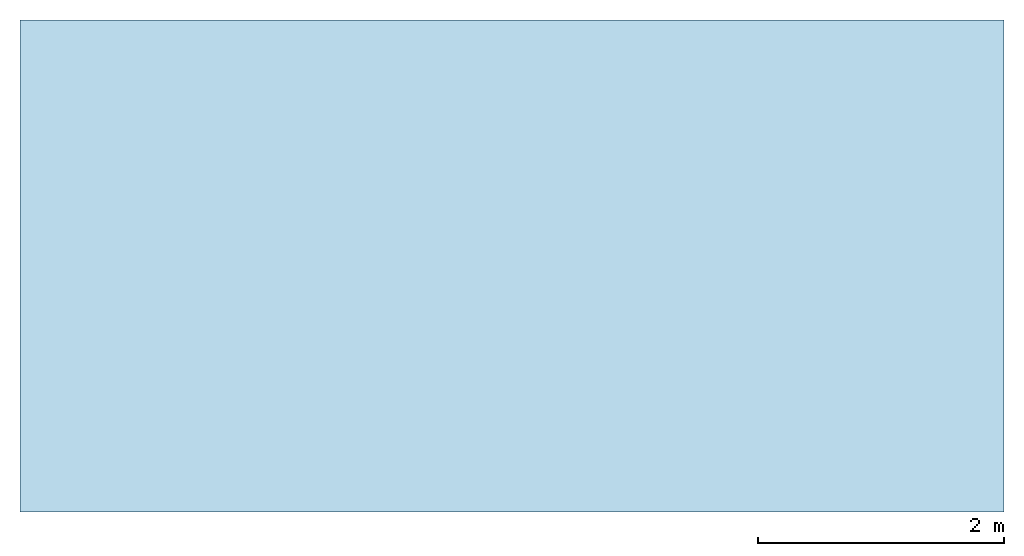
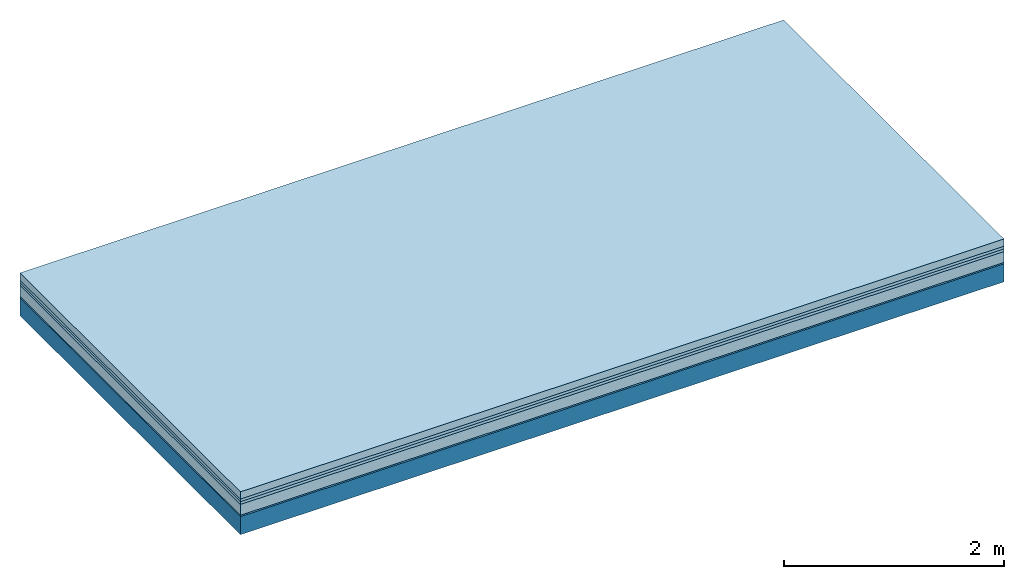
# One storey: 5 plates, 1 member, 1 element without a shape of its own.
"""IFC4 building model written with IfcOpenShell, lengths in metres."""

from ifc_helpers import new_model, si_unit, derived_unit, direction, frame, frame_2d, origin, origin_with_axes, place, context, project, spatial, rectangle, extrude, material, layer, layer_set, type_object, element, aggregate, save


model = new_model("IFC4")

# Units and contexts
plan_context = context("Plan", 3, precision=1e-05, world=origin(), true_north=direction((0.0, 1.0)))
model_context = context("Model", 3, precision=1e-05, world=origin(), true_north=direction((0.0, 1.0)))
ifc_project = project(units=[si_unit("LENGTHUNIT", "METRE"), derived_unit("SOUNDPRESSUREUNIT", [(si_unit("PRESSUREUNIT", "PASCAL", prefix="MICRO"), 0)]), si_unit("ENERGYUNIT", "JOULE", prefix="MEGA"), si_unit("MASSUNIT", "GRAM", prefix="KILO"), derived_unit("THERMALTRANSMITTANCEUNIT", [(si_unit("POWERUNIT", "WATT"), 1), (si_unit("AREAUNIT", "SQUARE_METRE"), -1), (si_unit("THERMODYNAMICTEMPERATUREUNIT", "KELVIN"), -1)]), derived_unit("AREADENSITYUNIT", [(si_unit("MASSUNIT", "GRAM", prefix="KILO"), 1), (si_unit("AREAUNIT", "SQUARE_METRE"), -1)]), derived_unit("USERDEFINED", [(si_unit("ENERGYUNIT", "JOULE", prefix="MEGA"), 1), (si_unit("AREAUNIT", "SQUARE_METRE"), -1)])], contexts=[plan_context, model_context])

# Site, building, storey
site = spatial("IfcSite", under=ifc_project)
building_placement = place(None, origin())
building = spatial("IfcBuilding", under=site, at=building_placement)
storey_placement = place(building_placement, origin())
storey = spatial("IfcBuildingStorey", under=building, at=storey_placement)

# Slab, member, plates
ifc_material_1 = material(Name="Cement screed", Category="04.006")
ifc_layer_1 = layer(ifc_material_1, 0.08, Name="On-material")
ifc_material_2 = material()
ifc_layer_2 = layer(ifc_material_2, 0.03, Name="Impact sound insulation")
ifc_material_3 = material()
ifc_layer_3 = layer(ifc_material_3, 0.03, Name="Additional insulation")
ifc_material_4 = material(Category="03.011")
ifc_layer_4 = layer(ifc_material_4, 0.12, Name="on Supporting structure")
ifc_material_5 = material(Category="03.007")
ifc_layer_5 = layer(ifc_material_5, 0.015, Name="Sub-floor")
ifc_material_6 = material(Name="of the art")
ifc_layer_6 = layer(ifc_material_6, 0.0, Name="Bond")
ifc_layer_7 = layer(None, 0.2, Name="Supporting structure")
ifc_layer_set = layer_set([ifc_layer_1, ifc_layer_2, ifc_layer_3, ifc_layer_4, ifc_layer_5, ifc_layer_6, ifc_layer_7])
slab_type = type_object("IfcSlabType", Name="A1102", PredefinedType="NOTDEFINED", material=ifc_layer_set)
slab_placement = place(None, frame((0.0, 0.0, 0.0), z_axis=(0.0, 0.0, -1.0), x_axis=(1.0, 0.0, 0.0)))
slab = element("IfcSlab", 1, at=slab_placement, inside=storey, type_object=slab_type, material=ifc_layer_set, Name="Slab #1")
ifc_material_7 = material()
member_placement = place(slab_placement, origin())
member = element("IfcMember", 2, at=member_placement, material=ifc_material_7, Name="Supporting structure", context=plan_context, shape_type="SweptSolid", body=[
    extrude(rectangle(XDim=1.0, YDim=0.2, at=frame_2d((0.5, 0.1), x_axis=(1.0, 0.0))), frame((0.0, 4.0, 0.275), z_axis=(0.0, -1.0, 0.0), x_axis=(1.0, 0.0, 0.0)), (0.0, 0.0, 1.0), 4.0),
    extrude(rectangle(XDim=1.0, YDim=0.2, at=frame_2d((0.5, 0.1), x_axis=(1.0, 0.0))), frame((1.0, 4.0, 0.275), z_axis=(0.0, -1.0, 0.0), x_axis=(1.0, 0.0, 0.0)), (0.0, 0.0, 1.0), 4.0),
    extrude(rectangle(XDim=1.0, YDim=0.2, at=frame_2d((0.5, 0.1), x_axis=(1.0, 0.0))), frame((2.0, 4.0, 0.275), z_axis=(0.0, -1.0, 0.0), x_axis=(1.0, 0.0, 0.0)), (0.0, 0.0, 1.0), 4.0),
    extrude(rectangle(XDim=1.0, YDim=0.2, at=frame_2d((0.5, 0.1), x_axis=(1.0, 0.0))), frame((3.0, 4.0, 0.275), z_axis=(0.0, -1.0, 0.0), x_axis=(1.0, 0.0, 0.0)), (0.0, 0.0, 1.0), 4.0),
    extrude(rectangle(XDim=1.0, YDim=0.2, at=frame_2d((0.5, 0.1), x_axis=(1.0, 0.0))), frame((4.0, 4.0, 0.275), z_axis=(0.0, -1.0, 0.0), x_axis=(1.0, 0.0, 0.0)), (0.0, 0.0, 1.0), 4.0),
    extrude(rectangle(XDim=1.0, YDim=0.2, at=frame_2d((0.5, 0.1), x_axis=(1.0, 0.0))), frame((5.0, 4.0, 0.275), z_axis=(0.0, -1.0, 0.0), x_axis=(1.0, 0.0, 0.0)), (0.0, 0.0, 1.0), 4.0),
    extrude(rectangle(XDim=1.0, YDim=0.2, at=frame_2d((0.5, 0.1), x_axis=(1.0, 0.0))), frame((6.0, 4.0, 0.275), z_axis=(0.0, -1.0, 0.0), x_axis=(1.0, 0.0, 0.0)), (0.0, 0.0, 1.0), 4.0),
    extrude(rectangle(XDim=1.0, YDim=0.2, at=frame_2d((0.5, 0.1), x_axis=(1.0, 0.0))), frame((7.0, 4.0, 0.275), z_axis=(0.0, -1.0, 0.0), x_axis=(1.0, 0.0, 0.0)), (0.0, 0.0, 1.0), 4.0),
])
plate_1_placement = place(slab_placement, origin())
plate_1 = element("IfcPlate", 3, at=plate_1_placement, material=ifc_material_1, Name="On-material", context=plan_context, shape_type="SweptSolid", body=[
    extrude(rectangle(XDim=8.0, YDim=4.0, at=frame_2d((4.0, 2.0), x_axis=(1.0, 0.0))), origin_with_axes(), (0.0, 0.0, 1.0), 0.08),
])
plate_2_placement = place(slab_placement, origin())
plate_2 = element("IfcPlate", 4, at=plate_2_placement, material=ifc_material_2, Name="Impact sound insulation", context=plan_context, shape_type="SweptSolid", body=[
    extrude(rectangle(XDim=8.0, YDim=4.0, at=frame_2d((4.0, 2.0), x_axis=(1.0, 0.0))), frame((0.0, 0.0, 0.08), z_axis=(0.0, 0.0, 1.0), x_axis=(1.0, 0.0, 0.0)), (0.0, 0.0, 1.0), 0.03),
])
plate_3_placement = place(slab_placement, origin())
plate_3 = element("IfcPlate", 5, at=plate_3_placement, material=ifc_material_3, Name="Additional insulation", context=plan_context, shape_type="SweptSolid", body=[
    extrude(rectangle(XDim=8.0, YDim=4.0, at=frame_2d((4.0, 2.0), x_axis=(1.0, 0.0))), frame((0.0, 0.0, 0.11), z_axis=(0.0, 0.0, 1.0), x_axis=(1.0, 0.0, 0.0)), (0.0, 0.0, 1.0), 0.03),
])
plate_4_placement = place(slab_placement, origin())
plate_4 = element("IfcPlate", 6, at=plate_4_placement, material=ifc_material_4, Name="on Supporting structure", context=plan_context, shape_type="SweptSolid", body=[
    extrude(rectangle(XDim=8.0, YDim=4.0, at=frame_2d((4.0, 2.0), x_axis=(1.0, 0.0))), frame((0.0, 0.0, 0.14), z_axis=(0.0, 0.0, 1.0), x_axis=(1.0, 0.0, 0.0)), (0.0, 0.0, 1.0), 0.12),
])
plate_5_placement = place(slab_placement, origin())
plate_5 = element("IfcPlate", 7, at=plate_5_placement, material=ifc_material_5, Name="Sub-floor", context=plan_context, shape_type="SweptSolid", body=[
    extrude(rectangle(XDim=8.0, YDim=4.0, at=frame_2d((4.0, 2.0), x_axis=(1.0, 0.0))), frame((0.0, 0.0, 0.26), z_axis=(0.0, 0.0, 1.0), x_axis=(1.0, 0.0, 0.0)), (0.0, 0.0, 1.0), 0.015),
])
aggregate(slab, [plate_1, plate_2, plate_3, plate_4, plate_5, member])

save(model, "model.ifc")
